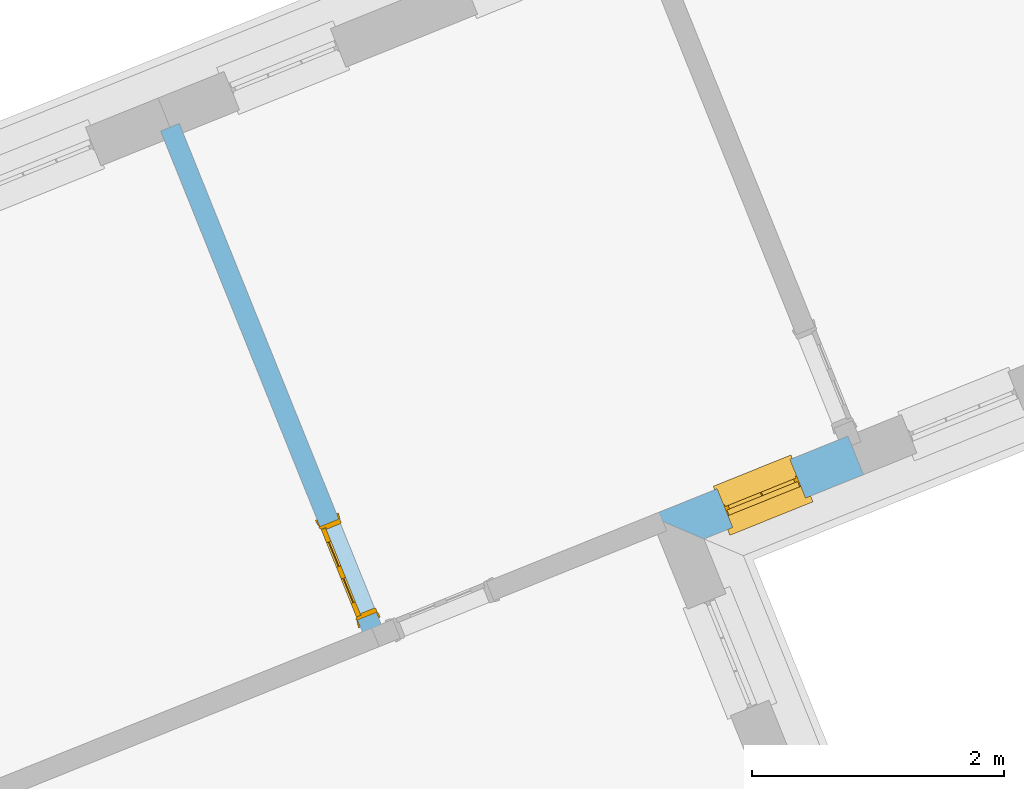
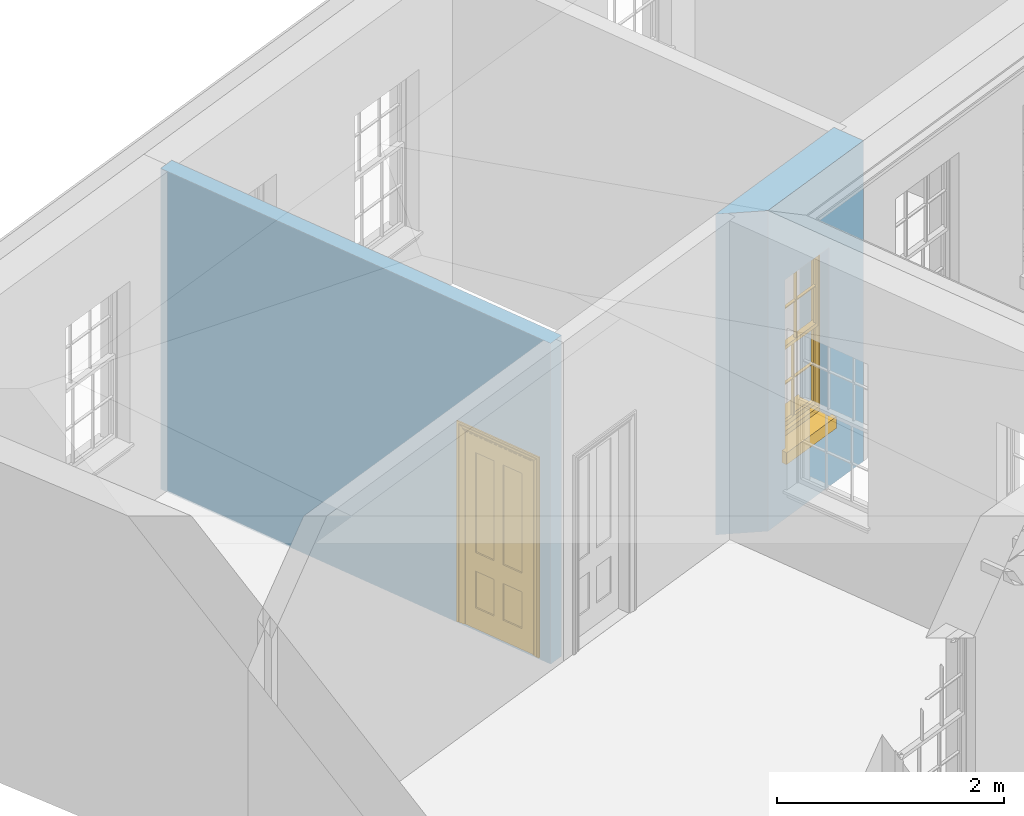
# One storey, part 6 of 11: 1 door, 1 window, 2 openings, plus 2 elements that do not belong to this part.
"""IFC2X3 building model written with IfcOpenShell, lengths in metres."""

from ifc_helpers import new_model, si_unit, frame, origin, place, context, subcontext, project, spatial, polyline, outline, extrude, faceted_brep, material, layer, layer_set, layer_usage, element, fill, save


model = new_model("IFC2X3")

# Units and contexts
model_context = context("Model", 3, world=origin())
body_context = subcontext(model_context, "Body", "Model", "MODEL_VIEW")
ifc_project = project(units=[si_unit("PLANEANGLEUNIT", "RADIAN"), si_unit("MASSUNIT", "GRAM", prefix="KILO"), si_unit("FORCEUNIT", "NEWTON", prefix="KILO"), si_unit("LENGTHUNIT", "METRE")], contexts=[model_context])

# Site, building, storey
site_placement = place(None, origin())
site = spatial("IfcSite", under=ifc_project, at=site_placement, CompositionType="ELEMENT")
building_placement = place(None, origin())
building = spatial("IfcBuilding", under=site, at=building_placement, Name="Building plot-6", CompositionType="ELEMENT")
storey_placement = place(None, frame((0.0, 0.0, 7.6)))
storey = spatial("IfcBuildingStorey", under=building, at=storey_placement, Name="Floor 1", CompositionType="ELEMENT", Elevation=7.6)

# Wall, opening, window
ifc_material_1 = material(Name="Masonry")
ifc_layer_1 = layer(ifc_material_1, 0.33, ventilated=False)
ifc_layer_set_1 = layer_set([ifc_layer_1], Name="My Wall")
ifc_layer_usage_1 = layer_usage(ifc_layer_set_1, "AXIS2", "NEGATIVE", 0.08)
wall_1_placement = place(storey_placement, origin())
wall_1 = element("IfcWallStandardCase", 1, at=wall_1_placement, inside=storey, material=ifc_layer_usage_1, Name="exterior", context=body_context, shape_type="SweptSolid", body=[
    extrude(outline(polyline([(71.3771473296118, 62.7015946274014), (71.8065811462563, 62.5188746308983), (73.0716100642196, 63.0287140049853), (72.9482531541489, 63.3347909115591), (71.3771473296118, 62.7015946274014)])), origin(), (0.0, 0.0, 1.0), 3.45),
])
opening_1_placement = place(storey_placement, frame((0.0, 0.0, 0.75)))
opening_1 = element("IfcOpeningElement", 2, at=opening_1_placement, cuts=wall_1, Name="Opening", ObjectType="Opening", context=body_context, shape_type="SweptSolid", body=[
    extrude(outline(polyline([(72.0333118275833, 62.6102529598935), (72.6130029385186, 62.8438834713911), (72.4896460284478, 63.1499603779649), (71.9099549175126, 62.9163298664673), (72.0333118275833, 62.6102529598935)])), origin(), (0.0, 0.0, 1.0), 1.82),
])
window_placement = place(storey_placement, frame((71.9398596229843, 62.8421294042676, 0.75), z_axis=(0.0, 0.0, 1.0), x_axis=(0.579691110935272, 0.233630511497594, 0.0)))
window = element("IfcWindow", 3, at=window_placement, inside=storey, Name="circulation outside window", OverallHeight=1.82, OverallWidth=0.625, context=body_context, shape_type="Brep", held_by="IfcProductRepresentation", body=[
    faceted_brep([(0.033125, -0.105, 0.975209), (0.01, -0.105, 0.975209), (0.033125, -0.105, 1.376042), (0.591875, -0.105, 0.975209), (0.591875, -0.105, 1.376042), (0.615, -0.105, 0.975209), (0.591875, -0.105, 1.386042), (0.591875, -0.105, 1.786875), (0.615, -0.105, 1.81), (0.033125, -0.105, 1.786875), (0.033125, -0.105, 1.386042), (0.01, -0.105, 1.81), (0.591875, -0.135, 1.376042), (0.591875, -0.135, 0.975209), (0.615, -0.135, 0.937083), (0.033125, -0.135, 1.786875), (0.01, -0.135, 1.81), (0.033125, -0.135, 1.386042), (0.01, -0.135, 0.937083), (0.033125, -0.135, 0.975209), (0.033125, -0.135, 1.376042), (0.591875, -0.135, 1.786875), (0.591875, -0.135, 1.386042), (0.615, -0.135, 1.81), (0.033125, -0.105, 0.937083), (0.01, -0.105, 0.937083), (0.033125, -0.105, 0.53625), (0.591875, -0.105, 0.937083), (0.591875, -0.105, 0.53625), (0.615, -0.105, 0.937083), (0.591875, -0.105, 0.52625), (0.591875, -0.105, 0.125417), (0.615, -0.105, 0.077167), (0.033125, -0.105, 0.125417), (0.033125, -0.105, 0.52625), (0.01, -0.105, 0.077167), (-0.0425, -0.25, 0.01), (-0.0425, -0.3, 0.001667), (0.0, -0.25, 0.01), (0.6675, -0.25, 0.01), (0.625, -0.25, 0.01), (0.6675, -0.3, 0.001667), (-0.02, 0.08, 0.077167), (0.0, 0.08, 0.077167), (-0.02, 0.11, 0.077167), (0.0, -0.06, 0.077167), (0.01, -0.06, 0.077167), (0.625, -0.06, 0.077167), (0.625, 0.08, 0.077167), (0.615, -0.06, 0.077167), (0.645, 0.08, 0.077167), (0.645, 0.11, 0.077167), (0.01, -0.075, 0.975209), (0.615, -0.075, 0.975209), (0.591875, -0.075, 0.125417), (0.591875, -0.075, 0.52625), (0.615, -0.075, 0.077167), (0.591875, -0.075, 0.53625), (0.591875, -0.075, 0.937083), (0.033125, -0.075, 0.125417), (0.01, -0.075, 0.077167), (0.033125, -0.075, 0.52625), (0.033125, -0.075, 0.937083), (0.033125, -0.075, 0.53625), (-0.02, 0.08, 0.052167), (-0.02, 0.11, 0.052167), (0.645, 0.11, 0.052167), (0.645, 0.08, 0.052167), (0.625, 0.08, 0.052167), (0.0, 0.08, 0.052167), (0.625, -0.15, 0.026667), (0.0, -0.15, 0.026667), (-0.0425, -0.3, -0.123333), (0.6675, -0.3, -0.123333), (-0.0425, -0.25, -0.123333), (0.6675, -0.25, -0.123333), (0.01, -0.06, 1.81), (0.615, -0.06, 1.81), (0.0, -0.06, 1.82), (0.625, -0.06, 1.82), (0.01, -0.15, 0.077167), (0.615, -0.15, 0.077167), (0.3175, -0.075, 0.53625), (0.3175, -0.105, 0.53625), (0.3175, -0.075, 0.52625), (0.3175, -0.075, 0.125417), (0.3075, -0.075, 0.125417), (0.3075, -0.075, 0.52625), (0.3075, -0.075, 0.53625), (0.3175, -0.075, 0.937083), (0.3075, -0.075, 0.937083), (0.3075, -0.105, 0.52625), (0.3075, -0.105, 0.125417), (0.3175, -0.105, 0.125417), (0.3175, -0.105, 0.52625), (0.3075, -0.105, 0.53625), (0.3075, -0.105, 0.937083), (0.3175, -0.105, 0.937083), (0.3075, -0.135, 1.386042), (0.3075, -0.135, 1.376042), (0.3175, -0.135, 1.376042), (0.3075, -0.135, 0.975209), (0.3175, -0.135, 0.975209), (0.3175, -0.135, 1.786875), (0.3075, -0.135, 1.786875), (0.3175, -0.135, 1.386042), (0.3175, -0.105, 1.386042), (0.3175, -0.105, 1.376042), (0.3075, -0.105, 1.386042), (0.3075, -0.105, 1.786875), (0.3175, -0.105, 1.786875), (0.3075, -0.105, 1.376042), (0.3175, -0.105, 0.975209), (0.3075, -0.105, 0.975209), (0.625, -0.15, 1.82), (0.615, -0.15, 1.81), (0.01, -0.15, 1.81), (0.0, -0.15, 1.82), (0.625, -0.25, 0.0), (0.0, -0.25, 0.0), (0.625, 0.08, 0.0), (0.0, 0.08, 0.0)], [[[0, 1, 2]], [[3, 4, 5]], [[6, 7, 8]], [[9, 10, 11]], [[12, 13, 14]], [[15, 16, 17]], [[18, 19, 20]], [[21, 22, 23]], [[24, 25, 26]], [[27, 28, 29]], [[30, 31, 32]], [[33, 34, 35]], [[14, 27, 29]], [[25, 24, 18]], [[36, 37, 38]], [[39, 40, 41]], [[42, 43, 44]], [[45, 46, 43]], [[47, 48, 49]], [[50, 51, 48]], [[1, 0, 52]], [[5, 53, 3]], [[54, 55, 56]], [[57, 58, 53]], [[59, 60, 61]], [[62, 63, 52]], [[48, 43, 46, 49]], [[51, 44, 43, 48]], [[64, 42, 44, 65]], [[65, 44, 51, 66]], [[66, 51, 50, 67]], [[65, 66, 68, 69]], [[60, 56, 49, 46]], [[70, 71, 38, 40]], [[37, 41, 40, 38]], [[37, 72, 73, 41]], [[74, 75, 73, 72]], [[8, 11, 76, 77]], [[76, 78, 79, 77]], [[32, 35, 80, 81]], [[81, 80, 71, 70]], [[28, 57, 82, 83]], [[84, 85, 86, 87]], [[88, 87, 61, 63]], [[89, 82, 88, 90]], [[84, 82, 57, 55]], [[91, 87, 86, 92]], [[34, 61, 87, 91]], [[93, 85, 84, 94]], [[95, 88, 63, 26]], [[96, 90, 88, 95]], [[83, 82, 89, 97]], [[94, 84, 55, 30]], [[94, 30, 28, 83]], [[94, 91, 92, 93]], [[95, 26, 34, 91]], [[97, 96, 95, 83]], [[98, 17, 20, 99]], [[100, 99, 101, 102]], [[103, 104, 98, 105]], [[100, 12, 22, 105]], [[106, 6, 4, 107]], [[106, 108, 109, 110]], [[111, 2, 10, 108]], [[112, 113, 111, 107]], [[99, 111, 113, 101]], [[20, 2, 111, 99]], [[102, 112, 107, 100]], [[98, 108, 10, 17]], [[104, 109, 108, 98]], [[105, 106, 110, 103]], [[22, 6, 106, 105]], [[100, 107, 4, 12]], [[82, 84, 87, 88]], [[83, 95, 91, 94]], [[99, 100, 105, 98]], [[107, 111, 108, 106]], [[92, 86, 59, 33]], [[15, 9, 109, 104]], [[103, 110, 7, 21]], [[31, 54, 85, 93]], [[36, 74, 72, 37]], [[39, 41, 73, 75]], [[18, 14, 102, 101]], [[23, 16, 104, 103]], [[85, 56, 60, 86]], [[52, 53, 89, 90]], [[53, 52, 113, 112]], [[11, 8, 110, 109]], [[14, 18, 96, 97]], [[2, 1, 11, 10]], [[8, 5, 4, 6]], [[57, 53, 56, 55]], [[60, 52, 63, 61]], [[26, 25, 35, 34]], [[32, 29, 28, 30]], [[14, 23, 22, 12]], [[18, 20, 17, 16]], [[19, 0, 2, 20]], [[17, 10, 9, 15]], [[12, 4, 3, 13]], [[21, 7, 6, 22]], [[27, 58, 57, 28]], [[30, 55, 54, 31]], [[33, 59, 61, 34]], [[26, 63, 62, 24]], [[5, 8, 77, 53]], [[76, 11, 1, 52]], [[46, 45, 78, 76]], [[49, 77, 79, 47]], [[70, 114, 115, 81]], [[71, 80, 116, 117]], [[19, 101, 113, 0]], [[102, 13, 3, 112]], [[90, 96, 24, 62]], [[29, 32, 81, 14]], [[80, 35, 25, 18]], [[60, 46, 76, 52]], [[77, 49, 56, 53]], [[23, 14, 81, 115]], [[16, 116, 80, 18]], [[92, 33, 35]], [[32, 31, 93]], [[32, 93, 92, 35]], [[14, 13, 102]], [[101, 19, 18]], [[103, 21, 23]], [[16, 15, 104]], [[109, 9, 11]], [[8, 7, 110]], [[23, 115, 116, 16]], [[114, 117, 116, 115]], [[90, 62, 52]], [[58, 89, 53]], [[27, 97, 89, 58]], [[85, 54, 56]], [[60, 59, 86]], [[97, 27, 14]], [[18, 24, 96]], [[52, 0, 113]], [[112, 3, 53]], [[79, 78, 117, 114]], [[78, 45, 71, 117]], [[114, 70, 47, 79]], [[118, 75, 74, 119]], [[68, 66, 67]], [[48, 68, 67, 50]], [[69, 64, 65]], [[42, 64, 69, 43]], [[69, 68, 120, 121]], [[70, 68, 48, 47]], [[118, 120, 68, 70]], [[43, 69, 71, 45]], [[69, 121, 119, 71]], [[120, 118, 119, 121]], [[38, 119, 74, 36]], [[71, 119, 38]], [[39, 75, 118, 40]], [[40, 118, 70]]]),
])
fill(opening_1, window)

# Wall, opening, door
ifc_material_2 = material(Name="Masonry")
ifc_layer_2 = layer(ifc_material_2, 0.16, ventilated=False)
ifc_layer_set_2 = layer_set([ifc_layer_2], Name="My Wall")
ifc_layer_usage_2 = layer_usage(ifc_layer_set_2, "AXIS2", "NEGATIVE", 0.08)
wall_2_placement = place(storey_placement, origin())
wall_2 = element("IfcWallStandardCase", 4, at=wall_2_placement, inside=storey, material=ifc_layer_usage_2, Name="interior", context=body_context, shape_type="SweptSolid", body=[
    extrude(outline(polyline([(69.1262075222864, 61.7081548321859), (69.2746084466858, 61.7679642431293), (67.6436462482614, 65.8147571155052), (67.495245323862, 65.7549477045618), (69.1262075222864, 61.7081548321859)])), origin(), (0.0, 0.0, 1.0), 3.45),
])
opening_2_placement = place(storey_placement, frame((0.0, 0.0, 0.0199999999999996)))
opening_2 = element("IfcOpeningElement", 5, at=opening_2_placement, cuts=wall_2, Name="Opening", ObjectType="Opening", context=body_context, shape_type="SweptSolid", body=[
    extrude(outline(polyline([(69.2073228593745, 61.9349152830787), (68.9082758046576, 62.6769199050758), (68.7598748802581, 62.6171104941324), (69.0589219349751, 61.8751058721353), (69.2073228593745, 61.9349152830787)])), origin(), (0.0, 0.0, 1.0), 2.1),
])
door_placement = place(storey_placement, frame((69.1331223971748, 61.905010577607, 0.0199999999999996), z_axis=(0.0, 0.0, 1.0), x_axis=(-0.299047054716937, 0.74200462199714, 0.0)))
door = element("IfcDoor", 6, at=door_placement, inside=storey, Name="bedroom inside door", OverallHeight=2.1, OverallWidth=0.8, context=body_context, shape_type="Brep", held_by="IfcProductRepresentation", body=[
    faceted_brep([(0.773, 0.08, 1.895), (0.66, 0.08, 1.895), (0.66, 0.08, 2.073), (0.773, 0.08, 2.073), (0.773, 0.08, 0.82), (0.66, 0.08, 0.82), (0.45, 0.08, 1.895), (0.45, 0.08, 2.073), (0.773, 0.08, 0.62), (0.66, 0.08, 0.62), (0.66, 0.065, 0.82), (0.66, 0.065, 1.895), (0.45, 0.065, 1.895), (0.35, 0.08, 1.895), (0.35, 0.08, 2.073), (0.773, 0.08, 0.225), (0.66, 0.08, 0.225), (0.45, 0.08, 0.62), (0.45, 0.08, 0.82), (0.45, 0.065, 0.82), (0.35, 0.08, 0.82), (0.14, 0.08, 2.073), (0.14, 0.08, 1.895), (0.773, 0.08, 0.0), (0.66, 0.08, 0.0), (0.66, 0.065, 0.225), (0.66, 0.065, 0.62), (0.45, 0.065, 0.62), (0.35, 0.08, 0.62), (0.35, 0.065, 0.82), (0.35, 0.065, 1.895), (0.14, 0.065, 1.895), (0.027, 0.08, 2.073), (0.027, 0.08, 1.895), (0.773, 0.042, 0.0), (0.66, 0.042, 0.0), (0.45, 0.08, 0.0), (0.45, 0.08, 0.225), (0.45, 0.065, 0.225), (0.35, 0.08, 0.225), (0.14, 0.08, 0.82), (0.14, 0.08, 0.62), (0.14, 0.065, 0.82), (0.027, 0.08, 0.82), (0.773, 0.042, 0.225), (0.66, 0.042, 0.225), (0.45, 0.042, 0.0), (0.35, 0.08, 0.0), (0.35, 0.065, 0.225), (0.35, 0.065, 0.62), (0.14, 0.065, 0.62), (0.027, 0.08, 0.62), (0.773, 0.042, 0.62), (0.66, 0.042, 0.62), (0.45, 0.042, 0.225), (0.35, 0.042, 0.0), (0.14, 0.08, 0.225), (0.14, 0.08, 0.0), (0.14, 0.065, 0.225), (0.027, 0.08, 0.225), (0.773, 0.042, 0.82), (0.66, 0.042, 0.82), (0.66, 0.057, 0.62), (0.66, 0.057, 0.225), (0.45, 0.057, 0.225), (0.35, 0.042, 0.225), (0.14, 0.042, 0.0), (0.027, 0.08, 0.0), (0.773, 0.042, 1.895), (0.66, 0.042, 1.895), (0.45, 0.042, 0.62), (0.45, 0.042, 0.82), (0.45, 0.057, 0.62), (0.35, 0.042, 0.62), (0.14, 0.042, 0.225), (0.027, 0.042, 0.0), (0.773, 0.042, 2.073), (0.66, 0.042, 2.073), (0.66, 0.057, 1.895), (0.66, 0.057, 0.82), (0.45, 0.057, 0.82), (0.35, 0.042, 0.82), (0.35, 0.057, 0.62), (0.35, 0.057, 0.225), (0.14, 0.057, 0.225), (0.027, 0.042, 0.225), (0.45, 0.042, 1.895), (0.45, 0.042, 2.073), (0.45, 0.057, 1.895), (0.35, 0.042, 1.895), (0.14, 0.042, 0.82), (0.14, 0.042, 0.62), (0.14, 0.057, 0.62), (0.027, 0.042, 0.62), (0.35, 0.042, 2.073), (0.35, 0.057, 1.895), (0.35, 0.057, 0.82), (0.14, 0.057, 0.82), (0.027, 0.042, 0.82), (0.14, 0.042, 2.073), (0.14, 0.042, 1.895), (0.14, 0.057, 1.895), (0.027, 0.042, 1.895), (0.027, 0.042, 2.073), (0.02, 0.085, 0.0), (0.005, 0.09, 0.0), (0.005, 0.09, 2.095), (0.02, 0.085, 2.08), (0.02, 0.08, 0.0), (0.0, 0.085, 0.0), (0.0, 0.085, 2.1), (0.795, 0.09, 2.095), (0.78, 0.085, 2.08), (0.02, 0.08, 2.08), (0.0, 0.08, 0.0), (-0.032, 0.095, 0.0), (-0.032, 0.095, 2.132), (0.8, 0.085, 2.1), (0.795, 0.09, 0.0), (0.78, 0.085, 0.0), (0.78, 0.08, 2.08), (0.04, 0.04, 0.0), (0.025, 0.04, 0.0), (0.025, 0.04, 2.075), (0.04, 0.04, 2.06), (-0.04, 0.09, 0.0), (-0.04, 0.09, 2.14), (0.832, 0.095, 2.132), (0.8, 0.085, 0.0), (0.78, 0.08, 0.0), (0.8, 0.08, 0.0), (0.86, 0.08, 0.0), (0.86, 0.08, 2.16), (0.8, 0.08, 2.1), (-0.06, 0.08, 2.16), (0.0, 0.08, 2.1), (-0.06, 0.08, 0.0), (-0.04, 0.095, 0.0), (-0.04, 0.095, 2.14), (0.84, 0.09, 2.14), (0.832, 0.095, 0.0), (0.84, 0.09, 0.0), (0.86, 0.095, 0.0), (0.86, 0.095, 2.16), (-0.06, 0.095, 2.16), (-0.06, 0.095, 0.0), (0.84, 0.095, 0.0), (0.84, 0.095, 2.14), (-0.025, -0.095, 0.0), (-0.025, -0.09, 0.0), (-0.025, -0.09, 2.125), (-0.025, -0.095, 2.125), (-0.017, -0.095, 0.0), (-0.017, -0.095, 2.117), (0.825, -0.09, 2.125), (0.825, -0.095, 2.125), (0.825, -0.095, 0.0), (0.845, -0.095, 0.0), (-0.045, -0.095, 2.145), (-0.045, -0.095, 0.0), (0.845, -0.095, 2.145), (0.015, -0.085, 0.0), (0.015, -0.085, 2.085), (0.817, -0.095, 2.117), (0.825, -0.09, 0.0), (0.845, -0.08, 0.0), (0.845, -0.08, 2.145), (-0.045, -0.08, 2.145), (-0.045, -0.08, 0.0), (0.02, -0.09, 0.0), (0.02, -0.09, 2.08), (0.785, -0.085, 2.085), (0.817, -0.095, 0.0), (0.8, -0.08, 0.0), (0.8, -0.08, 2.1), (0.0, -0.08, 2.1), (0.0, -0.08, 0.0), (0.035, -0.085, 0.0), (0.035, -0.085, 2.065), (0.78, -0.09, 2.08), (0.785, -0.085, 0.0), (0.775, 0.04, 2.075), (0.76, 0.04, 2.06), (0.035, -0.08, 2.065), (0.035, -0.08, 0.0), (0.765, -0.085, 2.065), (0.78, -0.09, 0.0), (0.765, -0.08, 0.0), (0.765, -0.08, 2.065), (0.765, -0.085, 0.0), (0.04, -0.08, 2.06), (0.04, -0.08, 0.0), (0.76, -0.08, 2.06), (0.76, -0.08, 0.0), (0.76, 0.04, 0.0), (0.775, 0.04, 0.0), (0.025, 0.08, 0.0), (0.025, 0.08, 2.075), (0.775, 0.08, 0.0), (0.775, 0.08, 2.075)], [[[0, 1, 2, 3]], [[1, 0, 4, 5]], [[1, 6, 7, 2]], [[8, 9, 5, 4]], [[1, 5, 10, 11]], [[6, 1, 11, 12]], [[6, 13, 14, 7]], [[15, 16, 9, 8]], [[9, 17, 18, 5]], [[5, 18, 19, 10]], [[10, 19, 12, 11]], [[18, 6, 12, 19]], [[18, 20, 13, 6]], [[21, 14, 13, 22]], [[23, 24, 16, 15]], [[9, 16, 25, 26]], [[17, 9, 26, 27]], [[17, 28, 20, 18]], [[13, 20, 29, 30]], [[22, 13, 30, 31]], [[32, 21, 22, 33]], [[34, 35, 24, 23]], [[24, 36, 37, 16]], [[16, 37, 38, 25]], [[25, 38, 27, 26]], [[37, 17, 27, 38]], [[37, 39, 28, 17]], [[40, 20, 28, 41]], [[20, 40, 42, 29]], [[31, 30, 29, 42]], [[40, 22, 31, 42]], [[33, 22, 40, 43]], [[35, 34, 44, 45]], [[35, 46, 36, 24]], [[36, 47, 39, 37]], [[28, 39, 48, 49]], [[41, 28, 49, 50]], [[43, 40, 41, 51]], [[45, 44, 52, 53]], [[46, 35, 45, 54]], [[46, 55, 47, 36]], [[56, 39, 47, 57]], [[39, 56, 58, 48]], [[50, 49, 48, 58]], [[56, 41, 50, 58]], [[51, 41, 56, 59]], [[53, 52, 60, 61]], [[45, 53, 62, 63]], [[54, 45, 63, 64]], [[55, 46, 54, 65]], [[55, 66, 57, 47]], [[59, 56, 57, 67]], [[61, 60, 68, 69]], [[70, 53, 61, 71]], [[53, 70, 72, 62]], [[72, 64, 63, 62]], [[70, 54, 64, 72]], [[65, 54, 70, 73]], [[65, 74, 66, 55]], [[67, 57, 66, 75]], [[69, 68, 76, 77]], [[61, 69, 78, 79]], [[71, 61, 79, 80]], [[73, 70, 71, 81]], [[65, 73, 82, 83]], [[74, 65, 83, 84]], [[74, 85, 75, 66]], [[86, 69, 77, 87]], [[69, 86, 88, 78]], [[88, 80, 79, 78]], [[86, 71, 80, 88]], [[81, 71, 86, 89]], [[73, 81, 90, 91]], [[73, 91, 92, 82]], [[83, 82, 92, 84]], [[91, 74, 84, 92]], [[91, 93, 85, 74]], [[89, 86, 87, 94]], [[81, 89, 95, 96]], [[90, 81, 96, 97]], [[90, 98, 93, 91]], [[94, 99, 100, 89]], [[89, 100, 101, 95]], [[101, 97, 96, 95]], [[100, 90, 97, 101]], [[100, 102, 98, 90]], [[99, 103, 102, 100]], [[32, 103, 99, 21]], [[102, 103, 32, 33]], [[98, 102, 33, 43]], [[21, 99, 94, 14]], [[94, 87, 7, 14]], [[7, 87, 77, 2]], [[76, 3, 2, 77]], [[43, 51, 93, 98]], [[51, 59, 85, 93]], [[67, 75, 85, 59]], [[34, 23, 15, 44]], [[44, 15, 8, 52]], [[52, 8, 4, 60]], [[0, 68, 60, 4]], [[0, 3, 76, 68]], [[104, 105, 106, 107]], [[104, 108, 109, 105]], [[105, 109, 110, 106]], [[107, 106, 111, 112]], [[107, 113, 108, 104]], [[114, 109, 108]], [[109, 115, 116, 110]], [[106, 110, 117, 111]], [[112, 111, 118, 119]], [[113, 107, 112, 120]], [[121, 122, 123, 124]], [[115, 109, 114, 125]], [[115, 125, 126, 116]], [[110, 116, 127, 117]], [[111, 117, 128, 118]], [[118, 128, 129, 119]], [[120, 112, 119, 129]], [[130, 129, 128]], [[130, 131, 132, 133]], [[133, 132, 134, 135]], [[135, 134, 136, 114]], [[136, 125, 114]], [[125, 137, 138, 126]], [[116, 126, 139, 127]], [[117, 127, 140, 128]], [[141, 130, 128, 140]], [[131, 130, 141]], [[131, 142, 143, 132]], [[132, 143, 144, 134]], [[134, 144, 145, 136]], [[137, 125, 136, 145]], [[143, 142, 146]], [[143, 146, 147]], [[137, 145, 144]], [[143, 147, 138]], [[138, 137, 144]], [[143, 138, 144]], [[126, 138, 147, 139]], [[127, 139, 141, 140]], [[142, 131, 141, 146]], [[139, 147, 146, 141]], [[148, 149, 150, 151]], [[149, 152, 153, 150]], [[151, 150, 154, 155]], [[155, 156, 157]], [[158, 159, 148]], [[158, 148, 151]], [[155, 157, 160]], [[158, 151, 155]], [[155, 160, 158]], [[152, 161, 162, 153]], [[150, 153, 163, 154]], [[155, 154, 164, 156]], [[156, 164, 165, 157]], [[157, 165, 166, 160]], [[160, 166, 167, 158]], [[158, 167, 168, 159]], [[161, 169, 170, 162]], [[153, 162, 171, 163]], [[154, 163, 172, 164]], [[165, 164, 173]], [[165, 173, 174, 166]], [[166, 174, 175, 167]], [[167, 175, 176, 168]], [[169, 177, 178, 170]], [[162, 170, 179, 171]], [[163, 171, 180, 172]], [[172, 180, 173, 164]], [[124, 123, 181, 182]], [[183, 178, 177, 184]], [[170, 178, 185, 179]], [[171, 179, 186, 180]], [[187, 173, 180]], [[185, 188, 187, 189]], [[188, 185, 178, 183]], [[179, 185, 189, 186]], [[189, 187, 180, 186]], [[190, 183, 184, 191]], [[192, 188, 183, 190]], [[191, 184, 122, 121]], [[124, 190, 191, 121]], [[193, 187, 188, 192]], [[182, 192, 190, 124]], [[184, 176, 122]], [[194, 195, 187, 193]], [[192, 182, 194, 193]], [[161, 176, 184]], [[114, 108, 122, 176]], [[173, 187, 195]], [[152, 149, 176, 161]], [[169, 161, 184, 177]], [[196, 122, 108]], [[176, 175, 135, 114]], [[173, 195, 129, 130]], [[176, 149, 168]], [[123, 122, 196, 197]], [[196, 108, 113, 197]], [[175, 174, 133, 135]], [[198, 129, 195]], [[133, 174, 173, 130]], [[159, 168, 149, 148]], [[181, 123, 197, 199]], [[197, 113, 120, 199]], [[199, 120, 129, 198]], [[195, 181, 199, 198]], [[195, 194, 182, 181]]]),
])
fill(opening_2, door)

save(model, "model.ifc")
